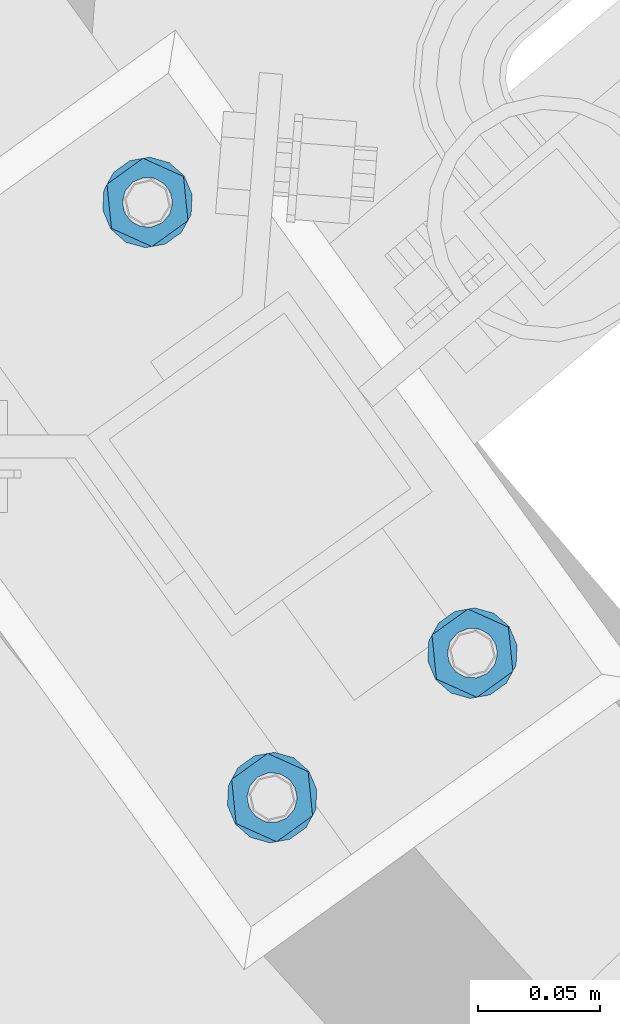
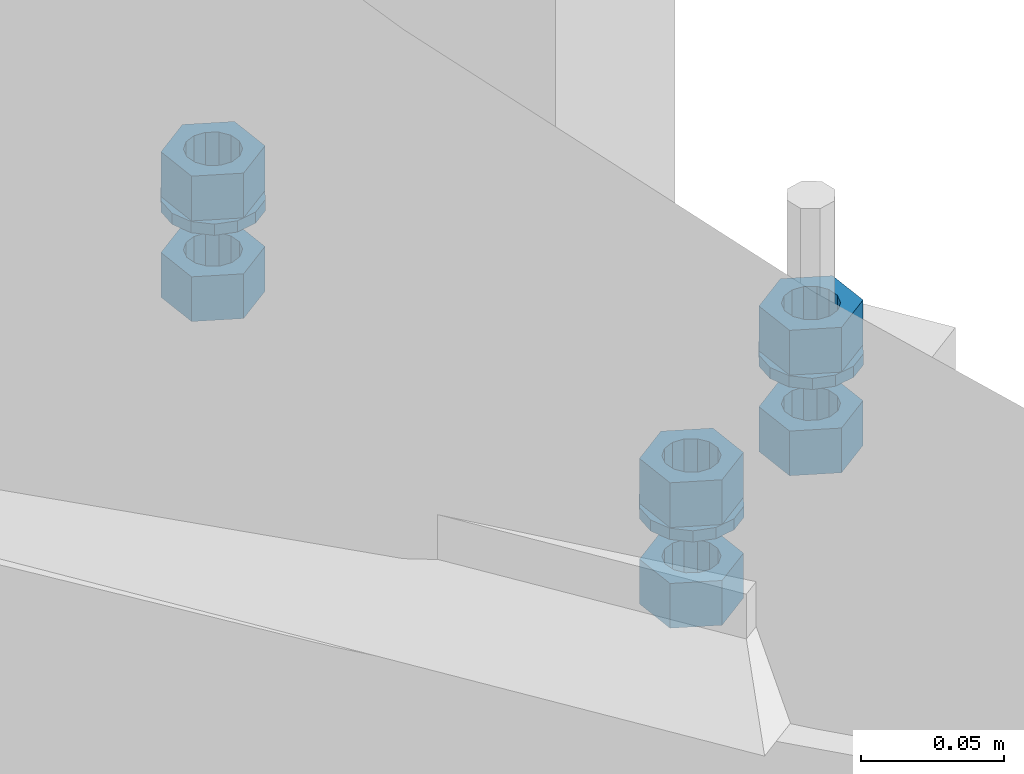
# One storey, part 658 of 975: 9 beams.
"""IFC2X3 building model written with IfcOpenShell, lengths in millimetres."""

from ifc_helpers import new_model, si_unit, frame, origin_with_axes, place, context, subcontext, project, spatial, faceted_brep, material, type_object, element, save


model = new_model("IFC2X3")

# Units and contexts
model_context = context("Model", 3, precision=1e-05, world=origin_with_axes())
body_context = subcontext(model_context, "Body", "Model", "MODEL_VIEW")
ifc_project = project(units=[si_unit("LENGTHUNIT", "METRE", prefix="MILLI"), si_unit("AREAUNIT", "SQUARE_METRE"), si_unit("VOLUMEUNIT", "CUBIC_METRE"), si_unit("MASSUNIT", "GRAM", prefix="KILO"), si_unit("TIMEUNIT", "SECOND"), si_unit("PLANEANGLEUNIT", "RADIAN"), si_unit("SOLIDANGLEUNIT", "STERADIAN"), si_unit("THERMODYNAMICTEMPERATUREUNIT", "DEGREE_CELSIUS"), si_unit("LUMINOUSINTENSITYUNIT", "LUMEN")], contexts=[model_context])

# Site, building, storey
site_placement = place(None, origin_with_axes())
site = spatial("IfcSite", under=ifc_project, at=site_placement, CompositionType="ELEMENT")
building_placement = place(site_placement, origin_with_axes())
building = spatial("IfcBuilding", under=site, at=building_placement, Name="Undefined", CompositionType="ELEMENT")
storey_placement = place(building_placement, origin_with_axes())
storey = spatial("IfcBuildingStorey", under=building, at=storey_placement, Name="Undefined", CompositionType="ELEMENT", Elevation=0.0)

# Beams
ifc_material = material(Name="STEEL/A36")
beam_type_1 = type_object("IfcBeamType", Name="3/4_WASHER", PredefinedType="NOTDEFINED")
beam_1_placement = place(storey_placement, frame((32237.717041171, 1287.18588232323, 1433.51249705359), z_axis=(-0.584817058957379, 0.811165215940897, 0.0), x_axis=(0.0, 0.0, -1.0)))
element("IfcBeam", 1, at=beam_1_placement, inside=storey, type_object=beam_type_1, material=ifc_material, Name="WASHER", ObjectType="3/4_WASHER", context=body_context, shape_type="Brep", body=[
    faceted_brep([(0.0, -18.6499996185303, 0.0), (0.0, -16.8030690426876, -8.09193156902904), (4.76250000000073, -16.8030690426876, -8.09193156902904), (4.76250000000073, -18.6499996185303, 0.0), (0.0, -11.6280845668225, -14.5811568497838), (4.76250000000073, -11.6280845668225, -14.5811568497838), (0.0, -4.15001533340001, -18.1824051902857), (4.76250000000073, -4.15001533340001, -18.1824051902857), (0.0, 4.15001533340001, -18.1824051902857), (4.76250000000073, 4.15001533340001, -18.1824051902857), (0.0, 11.6280845668234, -14.5811568497838), (4.76250000000073, 11.6280845668234, -14.5811568497838), (0.0, 16.8030690426876, -8.09193156902904), (4.76250000000073, 16.8030690426876, -8.09193156902904), (0.0, 18.6499996185303, 0.0), (4.76250000000073, 18.6499996185303, 0.0), (0.0, 16.8030690426876, 8.09193156902904), (4.76250000000073, 16.8030690426876, 8.09193156902904), (0.0, 11.6280845668225, 14.5811568497838), (4.76250000000073, 11.6280845668225, 14.5811568497838), (0.0, 4.15001533340001, 18.1824051902857), (4.76250000000073, 4.15001533340001, 18.1824051902857), (0.0, -4.15001533340001, 18.1824051902857), (4.76250000000073, -4.15001533340001, 18.1824051902857), (0.0, -11.6280845668234, 14.5811568497838), (4.76250000000073, -11.6280845668234, 14.5811568497838), (0.0, -16.8030690426876, 8.09193156902904), (4.76250000000073, -16.8030690426876, 8.09193156902904), (0.0, 0.0, 10.3199996948242), (0.0, 4.47768005528269, 9.29799844179911), (4.76250000000073, 4.47768005528269, 9.29799844179911), (4.76250000000073, 0.0, 10.3199996948242), (0.0, 8.06850066047446, 6.43441456490817), (4.76250000000073, 8.06850066047446, 6.43441456490817), (0.0, 10.0612557561917, 2.29641597052117), (4.76250000000073, 10.0612557561917, 2.29641597052117), (0.0, 10.0612557561917, -2.29641597052117), (4.76250000000073, 10.0612557561917, -2.29641597052117), (0.0, 8.06850066047446, -6.43441456490814), (4.76250000000073, 8.06850066047446, -6.43441456490814), (0.0, 4.47768005528269, -9.29799844179908), (4.76250000000073, 4.47768005528269, -9.29799844179908), (0.0, 0.0, -10.3199996948242), (4.76250000000073, 0.0, -10.3199996948242), (0.0, -4.47768005528269, -9.29799844179911), (4.76250000000073, -4.47768005528269, -9.29799844179911), (0.0, -8.06850066047446, -6.43441456490817), (4.76250000000073, -8.06850066047446, -6.43441456490817), (0.0, -10.0612557561917, -2.29641597052117), (4.76250000000073, -10.0612557561917, -2.29641597052117), (0.0, -10.0612557561917, 2.29641597052117), (4.76250000000073, -10.0612557561917, 2.29641597052117), (0.0, -8.06850066047446, 6.43441456490814), (4.76250000000073, -8.06850066047446, 6.43441456490814), (0.0, -4.47768005528269, 9.29799844179908), (4.76250000000073, -4.47768005528269, 9.29799844179908)], [[[0, 1, 2, 3]], [[1, 4, 5, 2]], [[4, 6, 7, 5]], [[6, 8, 9, 7]], [[8, 10, 11, 9]], [[10, 12, 13, 11]], [[12, 14, 15, 13]], [[14, 16, 17, 15]], [[16, 18, 19, 17]], [[18, 20, 21, 19]], [[20, 22, 23, 21]], [[22, 24, 25, 23]], [[24, 26, 27, 25]], [[26, 0, 3, 27]], [[28, 29, 30, 31]], [[29, 32, 33, 30]], [[32, 34, 35, 33]], [[34, 36, 37, 35]], [[36, 38, 39, 37]], [[38, 40, 41, 39]], [[40, 42, 43, 41]], [[42, 44, 45, 43]], [[44, 46, 47, 45]], [[46, 48, 49, 47]], [[48, 50, 51, 49]], [[50, 52, 53, 51]], [[52, 54, 55, 53]], [[54, 28, 31, 55]], [[5, 7, 9, 11, 13, 15, 17, 19, 21, 23, 25, 27, 3, 2], [33, 35, 37, 39, 41, 43, 45, 47, 49, 51, 53, 55, 31, 30]], [[26, 24, 22, 20, 18, 16, 14, 12, 10, 8, 6, 4, 1, 0], [54, 52, 50, 48, 46, 44, 42, 40, 38, 36, 34, 32, 29, 28]]]),
])
beam_2_placement = place(storey_placement, frame((32155.302659264, 1227.76846354077, 1433.51249705359), z_axis=(0.584817065277228, -0.811165211384543, 0.0), x_axis=(0.0, 0.0, -1.0)))
element("IfcBeam", 2, at=beam_2_placement, inside=storey, type_object=beam_type_1, material=ifc_material, Name="WASHER", ObjectType="3/4_WASHER", context=body_context, shape_type="Brep", body=[
    faceted_brep([(0.0, -18.6499996185303, 0.0), (0.0, -16.8030690426876, -8.09193156902904), (4.76250000000073, -16.8030690426876, -8.09193156902904), (4.76250000000073, -18.6499996185303, 0.0), (0.0, -11.6280845668225, -14.5811568497838), (4.76250000000073, -11.6280845668225, -14.5811568497838), (0.0, -4.15001533340001, -18.1824051902857), (4.76250000000073, -4.15001533340001, -18.1824051902857), (0.0, 4.15001533340001, -18.1824051902857), (4.76250000000073, 4.15001533340001, -18.1824051902857), (0.0, 11.6280845668234, -14.5811568497838), (4.76250000000073, 11.6280845668234, -14.5811568497838), (0.0, 16.8030690426876, -8.09193156902904), (4.76250000000073, 16.8030690426876, -8.09193156902904), (0.0, 18.6499996185303, 0.0), (4.76250000000073, 18.6499996185303, 0.0), (0.0, 16.8030690426876, 8.09193156902904), (4.76250000000073, 16.8030690426876, 8.09193156902904), (0.0, 11.6280845668225, 14.5811568497838), (4.76250000000073, 11.6280845668225, 14.5811568497838), (0.0, 4.15001533340001, 18.1824051902857), (4.76250000000073, 4.15001533340001, 18.1824051902857), (0.0, -4.15001533340001, 18.1824051902857), (4.76250000000073, -4.15001533340001, 18.1824051902857), (0.0, -11.6280845668234, 14.5811568497838), (4.76250000000073, -11.6280845668234, 14.5811568497838), (0.0, -16.8030690426876, 8.09193156902904), (4.76250000000073, -16.8030690426876, 8.09193156902904), (0.0, 0.0, 10.3199996948242), (0.0, 4.47768005528269, 9.29799844179911), (4.76250000000073, 4.47768005528269, 9.29799844179911), (4.76250000000073, 0.0, 10.3199996948242), (0.0, 8.06850066047446, 6.43441456490817), (4.76250000000073, 8.06850066047446, 6.43441456490817), (0.0, 10.0612557561917, 2.29641597052117), (4.76250000000073, 10.0612557561917, 2.29641597052117), (0.0, 10.0612557561917, -2.29641597052117), (4.76250000000073, 10.0612557561917, -2.29641597052117), (0.0, 8.06850066047446, -6.43441456490814), (4.76250000000073, 8.06850066047446, -6.43441456490814), (0.0, 4.47768005528269, -9.29799844179908), (4.76250000000073, 4.47768005528269, -9.29799844179908), (0.0, 0.0, -10.3199996948242), (4.76250000000073, 0.0, -10.3199996948242), (0.0, -4.47768005528269, -9.29799844179911), (4.76250000000073, -4.47768005528269, -9.29799844179911), (0.0, -8.06850066047446, -6.43441456490817), (4.76250000000073, -8.06850066047446, -6.43441456490817), (0.0, -10.0612557561917, -2.29641597052117), (4.76250000000073, -10.0612557561917, -2.29641597052117), (0.0, -10.0612557561917, 2.29641597052117), (4.76250000000073, -10.0612557561917, 2.29641597052117), (0.0, -8.06850066047446, 6.43441456490814), (4.76250000000073, -8.06850066047446, 6.43441456490814), (0.0, -4.47768005528269, 9.29799844179908), (4.76250000000073, -4.47768005528269, 9.29799844179908)], [[[0, 1, 2, 3]], [[1, 4, 5, 2]], [[4, 6, 7, 5]], [[6, 8, 9, 7]], [[8, 10, 11, 9]], [[10, 12, 13, 11]], [[12, 14, 15, 13]], [[14, 16, 17, 15]], [[16, 18, 19, 17]], [[18, 20, 21, 19]], [[20, 22, 23, 21]], [[22, 24, 25, 23]], [[24, 26, 27, 25]], [[26, 0, 3, 27]], [[28, 29, 30, 31]], [[29, 32, 33, 30]], [[32, 34, 35, 33]], [[34, 36, 37, 35]], [[36, 38, 39, 37]], [[38, 40, 41, 39]], [[40, 42, 43, 41]], [[42, 44, 45, 43]], [[44, 46, 47, 45]], [[46, 48, 49, 47]], [[48, 50, 51, 49]], [[50, 52, 53, 51]], [[52, 54, 55, 53]], [[54, 28, 31, 55]], [[5, 7, 9, 11, 13, 15, 17, 19, 21, 23, 25, 27, 3, 2], [33, 35, 37, 39, 41, 43, 45, 47, 49, 51, 53, 55, 31, 30]], [[26, 24, 22, 20, 18, 16, 14, 12, 10, 8, 6, 4, 1, 0], [54, 52, 50, 48, 46, 44, 42, 40, 38, 36, 34, 32, 29, 28]]]),
])
beam_3_placement = place(storey_placement, frame((32104.0278600483, 1472.6182496472, 1433.51249705359), z_axis=(-0.584817058957379, 0.811165215940897, 0.0), x_axis=(0.0, 0.0, -1.0)))
element("IfcBeam", 3, at=beam_3_placement, inside=storey, type_object=beam_type_1, material=ifc_material, Name="WASHER", ObjectType="3/4_WASHER", context=body_context, shape_type="Brep", body=[
    faceted_brep([(0.0, -18.6499996185303, 0.0), (0.0, -16.8030690426876, -8.09193156902904), (4.76250000000073, -16.8030690426876, -8.09193156902904), (4.76250000000073, -18.6499996185303, 0.0), (0.0, -11.6280845668225, -14.5811568497838), (4.76250000000073, -11.6280845668225, -14.5811568497838), (0.0, -4.15001533340001, -18.1824051902857), (4.76250000000073, -4.15001533340001, -18.1824051902857), (0.0, 4.15001533340001, -18.1824051902857), (4.76250000000073, 4.15001533340001, -18.1824051902857), (0.0, 11.6280845668234, -14.5811568497838), (4.76250000000073, 11.6280845668234, -14.5811568497838), (0.0, 16.8030690426876, -8.09193156902904), (4.76250000000073, 16.8030690426876, -8.09193156902904), (0.0, 18.6499996185303, 0.0), (4.76250000000073, 18.6499996185303, 0.0), (0.0, 16.8030690426876, 8.09193156902904), (4.76250000000073, 16.8030690426876, 8.09193156902904), (0.0, 11.6280845668225, 14.5811568497838), (4.76250000000073, 11.6280845668225, 14.5811568497838), (0.0, 4.15001533340001, 18.1824051902857), (4.76250000000073, 4.15001533340001, 18.1824051902857), (0.0, -4.15001533340001, 18.1824051902857), (4.76250000000073, -4.15001533340001, 18.1824051902857), (0.0, -11.6280845668234, 14.5811568497838), (4.76250000000073, -11.6280845668234, 14.5811568497838), (0.0, -16.8030690426876, 8.09193156902904), (4.76250000000073, -16.8030690426876, 8.09193156902904), (0.0, 0.0, 10.3199996948242), (0.0, 4.47768005528269, 9.29799844179911), (4.76250000000073, 4.47768005528269, 9.29799844179911), (4.76250000000073, 0.0, 10.3199996948242), (0.0, 8.06850066047446, 6.43441456490817), (4.76250000000073, 8.06850066047446, 6.43441456490817), (0.0, 10.0612557561917, 2.29641597052117), (4.76250000000073, 10.0612557561917, 2.29641597052117), (0.0, 10.0612557561917, -2.29641597052117), (4.76250000000073, 10.0612557561917, -2.29641597052117), (0.0, 8.06850066047446, -6.43441456490814), (4.76250000000073, 8.06850066047446, -6.43441456490814), (0.0, 4.47768005528269, -9.29799844179908), (4.76250000000073, 4.47768005528269, -9.29799844179908), (0.0, 0.0, -10.3199996948242), (4.76250000000073, 0.0, -10.3199996948242), (0.0, -4.47768005528269, -9.29799844179911), (4.76250000000073, -4.47768005528269, -9.29799844179911), (0.0, -8.06850066047446, -6.43441456490817), (4.76250000000073, -8.06850066047446, -6.43441456490817), (0.0, -10.0612557561917, -2.29641597052117), (4.76250000000073, -10.0612557561917, -2.29641597052117), (0.0, -10.0612557561917, 2.29641597052117), (4.76250000000073, -10.0612557561917, 2.29641597052117), (0.0, -8.06850066047446, 6.43441456490814), (4.76250000000073, -8.06850066047446, 6.43441456490814), (0.0, -4.47768005528269, 9.29799844179908), (4.76250000000073, -4.47768005528269, 9.29799844179908)], [[[0, 1, 2, 3]], [[1, 4, 5, 2]], [[4, 6, 7, 5]], [[6, 8, 9, 7]], [[8, 10, 11, 9]], [[10, 12, 13, 11]], [[12, 14, 15, 13]], [[14, 16, 17, 15]], [[16, 18, 19, 17]], [[18, 20, 21, 19]], [[20, 22, 23, 21]], [[22, 24, 25, 23]], [[24, 26, 27, 25]], [[26, 0, 3, 27]], [[28, 29, 30, 31]], [[29, 32, 33, 30]], [[32, 34, 35, 33]], [[34, 36, 37, 35]], [[36, 38, 39, 37]], [[38, 40, 41, 39]], [[40, 42, 43, 41]], [[42, 44, 45, 43]], [[44, 46, 47, 45]], [[46, 48, 49, 47]], [[48, 50, 51, 49]], [[50, 52, 53, 51]], [[52, 54, 55, 53]], [[54, 28, 31, 55]], [[5, 7, 9, 11, 13, 15, 17, 19, 21, 23, 25, 27, 3, 2], [33, 35, 37, 39, 41, 43, 45, 47, 49, 51, 53, 55, 31, 30]], [[26, 24, 22, 20, 18, 16, 14, 12, 10, 8, 6, 4, 1, 0], [54, 52, 50, 48, 46, 44, 42, 40, 38, 36, 34, 32, 29, 28]]]),
])
beam_type_2 = type_object("IfcBeamType", Name="3/4_HEAVY_HEX_NUT", PredefinedType="NOTDEFINED")
beam_4_placement = place(storey_placement, frame((32237.717041171, 1287.18588232323, 1452.56249705359), z_axis=(-0.584817058957379, 0.811165215940897, 0.0), x_axis=(0.0, 0.0, -1.0)))
element("IfcBeam", 4, at=beam_4_placement, inside=storey, type_object=beam_type_2, material=ifc_material, Name="NUT", ObjectType="3/4_HEAVY_HEX_NUT", context=body_context, shape_type="Brep", body=[
    faceted_brep([(0.0, -18.2600002288818, 0.0), (0.0, -9.13000011444092, -15.8100004196167), (19.0499999999993, -9.13000011444092, -15.8100004196167), (19.0499999999993, -18.2600002288818, 0.0), (0.0, 9.13000011444092, -15.8100004196167), (19.0499999999993, 9.13000011444092, -15.8100004196167), (0.0, 18.2600002288818, 0.0), (19.0499999999993, 18.2600002288818, 0.0), (0.0, 9.13000011444092, 15.8100004196167), (19.0499999999993, 9.13000011444092, 15.8100004196167), (0.0, -9.13000011444092, 15.8100004196167), (19.0499999999993, -9.13000011444092, 15.8100004196167), (0.0, 0.0, 10.3199996948242), (0.0, 4.47768005528269, 9.29799844179911), (19.0499999999993, 4.47768005528269, 9.29799844179911), (19.0499999999993, 0.0, 10.3199996948242), (0.0, 8.06850066047446, 6.43441456490817), (19.0499999999993, 8.06850066047446, 6.43441456490817), (0.0, 10.0612557561917, 2.29641597052117), (19.0499999999993, 10.0612557561917, 2.29641597052117), (0.0, 10.0612557561917, -2.29641597052117), (19.0499999999993, 10.0612557561917, -2.29641597052117), (0.0, 8.06850066047446, -6.43441456490814), (19.0499999999993, 8.06850066047446, -6.43441456490814), (0.0, 4.47768005528269, -9.29799844179908), (19.0499999999993, 4.47768005528269, -9.29799844179908), (0.0, 0.0, -10.3199996948242), (19.0499999999993, 0.0, -10.3199996948242), (0.0, -4.47768005528269, -9.29799844179911), (19.0499999999993, -4.47768005528269, -9.29799844179911), (0.0, -8.06850066047446, -6.43441456490817), (19.0499999999993, -8.06850066047446, -6.43441456490817), (0.0, -10.0612557561917, -2.29641597052117), (19.0499999999993, -10.0612557561917, -2.29641597052117), (0.0, -10.0612557561917, 2.29641597052117), (19.0499999999993, -10.0612557561917, 2.29641597052117), (0.0, -8.06850066047446, 6.43441456490814), (19.0499999999993, -8.06850066047446, 6.43441456490814), (0.0, -4.47768005528269, 9.29799844179908), (19.0499999999993, -4.47768005528269, 9.29799844179908)], [[[0, 1, 2, 3]], [[1, 4, 5, 2]], [[4, 6, 7, 5]], [[6, 8, 9, 7]], [[8, 10, 11, 9]], [[10, 0, 3, 11]], [[12, 13, 14, 15]], [[13, 16, 17, 14]], [[16, 18, 19, 17]], [[18, 20, 21, 19]], [[20, 22, 23, 21]], [[22, 24, 25, 23]], [[24, 26, 27, 25]], [[26, 28, 29, 27]], [[28, 30, 31, 29]], [[30, 32, 33, 31]], [[32, 34, 35, 33]], [[34, 36, 37, 35]], [[36, 38, 39, 37]], [[38, 12, 15, 39]], [[5, 7, 9, 11, 3, 2], [17, 19, 21, 23, 25, 27, 29, 31, 33, 35, 37, 39, 15, 14]], [[10, 8, 6, 4, 1, 0], [38, 36, 34, 32, 30, 28, 26, 24, 22, 20, 18, 16, 13, 12]]]),
])
beam_5_placement = place(storey_placement, frame((32237.717041171, 1287.18588232323, 1409.69999705359), z_axis=(-0.584817058957379, 0.811165215940897, 0.0), x_axis=(0.0, 0.0, -1.0)))
element("IfcBeam", 5, at=beam_5_placement, inside=storey, type_object=beam_type_2, material=ifc_material, Name="NUT", ObjectType="3/4_HEAVY_HEX_NUT", context=body_context, shape_type="Brep", body=[
    faceted_brep([(0.0, -18.2600002288818, 0.0), (0.0, -9.13000011444092, -15.8100004196167), (19.0499999999993, -9.13000011444092, -15.8100004196167), (19.0499999999993, -18.2600002288818, 0.0), (0.0, 9.13000011444092, -15.8100004196167), (19.0499999999993, 9.13000011444092, -15.8100004196167), (0.0, 18.2600002288818, 0.0), (19.0499999999993, 18.2600002288818, 0.0), (0.0, 9.13000011444092, 15.8100004196167), (19.0499999999993, 9.13000011444092, 15.8100004196167), (0.0, -9.13000011444092, 15.8100004196167), (19.0499999999993, -9.13000011444092, 15.8100004196167), (0.0, 0.0, 10.3199996948242), (0.0, 4.47768005528269, 9.29799844179911), (19.0499999999993, 4.47768005528269, 9.29799844179911), (19.0499999999993, 0.0, 10.3199996948242), (0.0, 8.06850066047446, 6.43441456490817), (19.0499999999993, 8.06850066047446, 6.43441456490817), (0.0, 10.0612557561917, 2.29641597052117), (19.0499999999993, 10.0612557561917, 2.29641597052117), (0.0, 10.0612557561917, -2.29641597052117), (19.0499999999993, 10.0612557561917, -2.29641597052117), (0.0, 8.06850066047446, -6.43441456490814), (19.0499999999993, 8.06850066047446, -6.43441456490814), (0.0, 4.47768005528269, -9.29799844179908), (19.0499999999993, 4.47768005528269, -9.29799844179908), (0.0, 0.0, -10.3199996948242), (19.0499999999993, 0.0, -10.3199996948242), (0.0, -4.47768005528269, -9.29799844179911), (19.0499999999993, -4.47768005528269, -9.29799844179911), (0.0, -8.06850066047446, -6.43441456490817), (19.0499999999993, -8.06850066047446, -6.43441456490817), (0.0, -10.0612557561917, -2.29641597052117), (19.0499999999993, -10.0612557561917, -2.29641597052117), (0.0, -10.0612557561917, 2.29641597052117), (19.0499999999993, -10.0612557561917, 2.29641597052117), (0.0, -8.06850066047446, 6.43441456490814), (19.0499999999993, -8.06850066047446, 6.43441456490814), (0.0, -4.47768005528269, 9.29799844179908), (19.0499999999993, -4.47768005528269, 9.29799844179908)], [[[0, 1, 2, 3]], [[1, 4, 5, 2]], [[4, 6, 7, 5]], [[6, 8, 9, 7]], [[8, 10, 11, 9]], [[10, 0, 3, 11]], [[12, 13, 14, 15]], [[13, 16, 17, 14]], [[16, 18, 19, 17]], [[18, 20, 21, 19]], [[20, 22, 23, 21]], [[22, 24, 25, 23]], [[24, 26, 27, 25]], [[26, 28, 29, 27]], [[28, 30, 31, 29]], [[30, 32, 33, 31]], [[32, 34, 35, 33]], [[34, 36, 37, 35]], [[36, 38, 39, 37]], [[38, 12, 15, 39]], [[5, 7, 9, 11, 3, 2], [17, 19, 21, 23, 25, 27, 29, 31, 33, 35, 37, 39, 15, 14]], [[10, 8, 6, 4, 1, 0], [38, 36, 34, 32, 30, 28, 26, 24, 22, 20, 18, 16, 13, 12]]]),
])
beam_6_placement = place(storey_placement, frame((32155.302659264, 1227.76846354077, 1452.56249705359), z_axis=(0.584817065277228, -0.811165211384543, 0.0), x_axis=(0.0, 0.0, -1.0)))
element("IfcBeam", 6, at=beam_6_placement, inside=storey, type_object=beam_type_2, material=ifc_material, Name="NUT", ObjectType="3/4_HEAVY_HEX_NUT", context=body_context, shape_type="Brep", body=[
    faceted_brep([(0.0, -18.2600002288818, 0.0), (0.0, -9.13000011444092, -15.8100004196167), (19.0499999999993, -9.13000011444092, -15.8100004196167), (19.0499999999993, -18.2600002288818, 0.0), (0.0, 9.13000011444092, -15.8100004196167), (19.0499999999993, 9.13000011444092, -15.8100004196167), (0.0, 18.2600002288818, 0.0), (19.0499999999993, 18.2600002288818, 0.0), (0.0, 9.13000011444092, 15.8100004196167), (19.0499999999993, 9.13000011444092, 15.8100004196167), (0.0, -9.13000011444092, 15.8100004196167), (19.0499999999993, -9.13000011444092, 15.8100004196167), (0.0, 0.0, 10.3199996948242), (0.0, 4.47768005528269, 9.29799844179911), (19.0499999999993, 4.47768005528269, 9.29799844179911), (19.0499999999993, 0.0, 10.3199996948242), (0.0, 8.06850066047446, 6.43441456490817), (19.0499999999993, 8.06850066047446, 6.43441456490817), (0.0, 10.0612557561917, 2.29641597052117), (19.0499999999993, 10.0612557561917, 2.29641597052117), (0.0, 10.0612557561917, -2.29641597052117), (19.0499999999993, 10.0612557561917, -2.29641597052117), (0.0, 8.06850066047446, -6.43441456490814), (19.0499999999993, 8.06850066047446, -6.43441456490814), (0.0, 4.47768005528269, -9.29799844179908), (19.0499999999993, 4.47768005528269, -9.29799844179908), (0.0, 0.0, -10.3199996948242), (19.0499999999993, 0.0, -10.3199996948242), (0.0, -4.47768005528269, -9.29799844179911), (19.0499999999993, -4.47768005528269, -9.29799844179911), (0.0, -8.06850066047446, -6.43441456490817), (19.0499999999993, -8.06850066047446, -6.43441456490817), (0.0, -10.0612557561917, -2.29641597052117), (19.0499999999993, -10.0612557561917, -2.29641597052117), (0.0, -10.0612557561917, 2.29641597052117), (19.0499999999993, -10.0612557561917, 2.29641597052117), (0.0, -8.06850066047446, 6.43441456490814), (19.0499999999993, -8.06850066047446, 6.43441456490814), (0.0, -4.47768005528269, 9.29799844179908), (19.0499999999993, -4.47768005528269, 9.29799844179908)], [[[0, 1, 2, 3]], [[1, 4, 5, 2]], [[4, 6, 7, 5]], [[6, 8, 9, 7]], [[8, 10, 11, 9]], [[10, 0, 3, 11]], [[12, 13, 14, 15]], [[13, 16, 17, 14]], [[16, 18, 19, 17]], [[18, 20, 21, 19]], [[20, 22, 23, 21]], [[22, 24, 25, 23]], [[24, 26, 27, 25]], [[26, 28, 29, 27]], [[28, 30, 31, 29]], [[30, 32, 33, 31]], [[32, 34, 35, 33]], [[34, 36, 37, 35]], [[36, 38, 39, 37]], [[38, 12, 15, 39]], [[5, 7, 9, 11, 3, 2], [17, 19, 21, 23, 25, 27, 29, 31, 33, 35, 37, 39, 15, 14]], [[10, 8, 6, 4, 1, 0], [38, 36, 34, 32, 30, 28, 26, 24, 22, 20, 18, 16, 13, 12]]]),
])
beam_7_placement = place(storey_placement, frame((32104.0278600483, 1472.6182496472, 1452.56249705359), z_axis=(-0.584817058957379, 0.811165215940897, 0.0), x_axis=(0.0, 0.0, -1.0)))
element("IfcBeam", 7, at=beam_7_placement, inside=storey, type_object=beam_type_2, material=ifc_material, Name="NUT", ObjectType="3/4_HEAVY_HEX_NUT", context=body_context, shape_type="Brep", body=[
    faceted_brep([(0.0, -18.2600002288818, 0.0), (0.0, -9.13000011444092, -15.8100004196167), (19.0499999999993, -9.13000011444092, -15.8100004196167), (19.0499999999993, -18.2600002288818, 0.0), (0.0, 9.13000011444092, -15.8100004196167), (19.0499999999993, 9.13000011444092, -15.8100004196167), (0.0, 18.2600002288818, 0.0), (19.0499999999993, 18.2600002288818, 0.0), (0.0, 9.13000011444092, 15.8100004196167), (19.0499999999993, 9.13000011444092, 15.8100004196167), (0.0, -9.13000011444092, 15.8100004196167), (19.0499999999993, -9.13000011444092, 15.8100004196167), (0.0, 0.0, 10.3199996948242), (0.0, 4.47768005528269, 9.29799844179911), (19.0499999999993, 4.47768005528269, 9.29799844179911), (19.0499999999993, 0.0, 10.3199996948242), (0.0, 8.06850066047446, 6.43441456490817), (19.0499999999993, 8.06850066047446, 6.43441456490817), (0.0, 10.0612557561917, 2.29641597052117), (19.0499999999993, 10.0612557561917, 2.29641597052117), (0.0, 10.0612557561917, -2.29641597052117), (19.0499999999993, 10.0612557561917, -2.29641597052117), (0.0, 8.06850066047446, -6.43441456490814), (19.0499999999993, 8.06850066047446, -6.43441456490814), (0.0, 4.47768005528269, -9.29799844179908), (19.0499999999993, 4.47768005528269, -9.29799844179908), (0.0, 0.0, -10.3199996948242), (19.0499999999993, 0.0, -10.3199996948242), (0.0, -4.47768005528269, -9.29799844179911), (19.0499999999993, -4.47768005528269, -9.29799844179911), (0.0, -8.06850066047446, -6.43441456490817), (19.0499999999993, -8.06850066047446, -6.43441456490817), (0.0, -10.0612557561917, -2.29641597052117), (19.0499999999993, -10.0612557561917, -2.29641597052117), (0.0, -10.0612557561917, 2.29641597052117), (19.0499999999993, -10.0612557561917, 2.29641597052117), (0.0, -8.06850066047446, 6.43441456490814), (19.0499999999993, -8.06850066047446, 6.43441456490814), (0.0, -4.47768005528269, 9.29799844179908), (19.0499999999993, -4.47768005528269, 9.29799844179908)], [[[0, 1, 2, 3]], [[1, 4, 5, 2]], [[4, 6, 7, 5]], [[6, 8, 9, 7]], [[8, 10, 11, 9]], [[10, 0, 3, 11]], [[12, 13, 14, 15]], [[13, 16, 17, 14]], [[16, 18, 19, 17]], [[18, 20, 21, 19]], [[20, 22, 23, 21]], [[22, 24, 25, 23]], [[24, 26, 27, 25]], [[26, 28, 29, 27]], [[28, 30, 31, 29]], [[30, 32, 33, 31]], [[32, 34, 35, 33]], [[34, 36, 37, 35]], [[36, 38, 39, 37]], [[38, 12, 15, 39]], [[5, 7, 9, 11, 3, 2], [17, 19, 21, 23, 25, 27, 29, 31, 33, 35, 37, 39, 15, 14]], [[10, 8, 6, 4, 1, 0], [38, 36, 34, 32, 30, 28, 26, 24, 22, 20, 18, 16, 13, 12]]]),
])
beam_8_placement = place(storey_placement, frame((32155.302659264, 1227.76846354077, 1409.69999705359), z_axis=(0.584817065277228, -0.811165211384543, 0.0), x_axis=(0.0, 0.0, -1.0)))
element("IfcBeam", 8, at=beam_8_placement, inside=storey, type_object=beam_type_2, material=ifc_material, Name="NUT", ObjectType="3/4_HEAVY_HEX_NUT", context=body_context, shape_type="Brep", body=[
    faceted_brep([(0.0, -18.2600002288818, 0.0), (0.0, -9.13000011444092, -15.8100004196167), (19.0499999999993, -9.13000011444092, -15.8100004196167), (19.0499999999993, -18.2600002288818, 0.0), (0.0, 9.13000011444092, -15.8100004196167), (19.0499999999993, 9.13000011444092, -15.8100004196167), (0.0, 18.2600002288818, 0.0), (19.0499999999993, 18.2600002288818, 0.0), (0.0, 9.13000011444092, 15.8100004196167), (19.0499999999993, 9.13000011444092, 15.8100004196167), (0.0, -9.13000011444092, 15.8100004196167), (19.0499999999993, -9.13000011444092, 15.8100004196167), (0.0, 0.0, 10.3199996948242), (0.0, 4.47768005528269, 9.29799844179911), (19.0499999999993, 4.47768005528269, 9.29799844179911), (19.0499999999993, 0.0, 10.3199996948242), (0.0, 8.06850066047446, 6.43441456490817), (19.0499999999993, 8.06850066047446, 6.43441456490817), (0.0, 10.0612557561917, 2.29641597052117), (19.0499999999993, 10.0612557561917, 2.29641597052117), (0.0, 10.0612557561917, -2.29641597052117), (19.0499999999993, 10.0612557561917, -2.29641597052117), (0.0, 8.06850066047446, -6.43441456490814), (19.0499999999993, 8.06850066047446, -6.43441456490814), (0.0, 4.47768005528269, -9.29799844179908), (19.0499999999993, 4.47768005528269, -9.29799844179908), (0.0, 0.0, -10.3199996948242), (19.0499999999993, 0.0, -10.3199996948242), (0.0, -4.47768005528269, -9.29799844179911), (19.0499999999993, -4.47768005528269, -9.29799844179911), (0.0, -8.06850066047446, -6.43441456490817), (19.0499999999993, -8.06850066047446, -6.43441456490817), (0.0, -10.0612557561917, -2.29641597052117), (19.0499999999993, -10.0612557561917, -2.29641597052117), (0.0, -10.0612557561917, 2.29641597052117), (19.0499999999993, -10.0612557561917, 2.29641597052117), (0.0, -8.06850066047446, 6.43441456490814), (19.0499999999993, -8.06850066047446, 6.43441456490814), (0.0, -4.47768005528269, 9.29799844179908), (19.0499999999993, -4.47768005528269, 9.29799844179908)], [[[0, 1, 2, 3]], [[1, 4, 5, 2]], [[4, 6, 7, 5]], [[6, 8, 9, 7]], [[8, 10, 11, 9]], [[10, 0, 3, 11]], [[12, 13, 14, 15]], [[13, 16, 17, 14]], [[16, 18, 19, 17]], [[18, 20, 21, 19]], [[20, 22, 23, 21]], [[22, 24, 25, 23]], [[24, 26, 27, 25]], [[26, 28, 29, 27]], [[28, 30, 31, 29]], [[30, 32, 33, 31]], [[32, 34, 35, 33]], [[34, 36, 37, 35]], [[36, 38, 39, 37]], [[38, 12, 15, 39]], [[5, 7, 9, 11, 3, 2], [17, 19, 21, 23, 25, 27, 29, 31, 33, 35, 37, 39, 15, 14]], [[10, 8, 6, 4, 1, 0], [38, 36, 34, 32, 30, 28, 26, 24, 22, 20, 18, 16, 13, 12]]]),
])
beam_9_placement = place(storey_placement, frame((32104.0278600483, 1472.6182496472, 1409.69999705359), z_axis=(-0.584817058957379, 0.811165215940897, 0.0), x_axis=(0.0, 0.0, -1.0)))
element("IfcBeam", 9, at=beam_9_placement, inside=storey, type_object=beam_type_2, material=ifc_material, Name="NUT", ObjectType="3/4_HEAVY_HEX_NUT", context=body_context, shape_type="Brep", body=[
    faceted_brep([(0.0, -18.2600002288818, 0.0), (0.0, -9.13000011444092, -15.8100004196167), (19.0499999999993, -9.13000011444092, -15.8100004196167), (19.0499999999993, -18.2600002288818, 0.0), (0.0, 9.13000011444092, -15.8100004196167), (19.0499999999993, 9.13000011444092, -15.8100004196167), (0.0, 18.2600002288818, 0.0), (19.0499999999993, 18.2600002288818, 0.0), (0.0, 9.13000011444092, 15.8100004196167), (19.0499999999993, 9.13000011444092, 15.8100004196167), (0.0, -9.13000011444092, 15.8100004196167), (19.0499999999993, -9.13000011444092, 15.8100004196167), (0.0, 0.0, 10.3199996948242), (0.0, 4.47768005528269, 9.29799844179911), (19.0499999999993, 4.47768005528269, 9.29799844179911), (19.0499999999993, 0.0, 10.3199996948242), (0.0, 8.06850066047446, 6.43441456490817), (19.0499999999993, 8.06850066047446, 6.43441456490817), (0.0, 10.0612557561917, 2.29641597052117), (19.0499999999993, 10.0612557561917, 2.29641597052117), (0.0, 10.0612557561917, -2.29641597052117), (19.0499999999993, 10.0612557561917, -2.29641597052117), (0.0, 8.06850066047446, -6.43441456490814), (19.0499999999993, 8.06850066047446, -6.43441456490814), (0.0, 4.47768005528269, -9.29799844179908), (19.0499999999993, 4.47768005528269, -9.29799844179908), (0.0, 0.0, -10.3199996948242), (19.0499999999993, 0.0, -10.3199996948242), (0.0, -4.47768005528269, -9.29799844179911), (19.0499999999993, -4.47768005528269, -9.29799844179911), (0.0, -8.06850066047446, -6.43441456490817), (19.0499999999993, -8.06850066047446, -6.43441456490817), (0.0, -10.0612557561917, -2.29641597052117), (19.0499999999993, -10.0612557561917, -2.29641597052117), (0.0, -10.0612557561917, 2.29641597052117), (19.0499999999993, -10.0612557561917, 2.29641597052117), (0.0, -8.06850066047446, 6.43441456490814), (19.0499999999993, -8.06850066047446, 6.43441456490814), (0.0, -4.47768005528269, 9.29799844179908), (19.0499999999993, -4.47768005528269, 9.29799844179908)], [[[0, 1, 2, 3]], [[1, 4, 5, 2]], [[4, 6, 7, 5]], [[6, 8, 9, 7]], [[8, 10, 11, 9]], [[10, 0, 3, 11]], [[12, 13, 14, 15]], [[13, 16, 17, 14]], [[16, 18, 19, 17]], [[18, 20, 21, 19]], [[20, 22, 23, 21]], [[22, 24, 25, 23]], [[24, 26, 27, 25]], [[26, 28, 29, 27]], [[28, 30, 31, 29]], [[30, 32, 33, 31]], [[32, 34, 35, 33]], [[34, 36, 37, 35]], [[36, 38, 39, 37]], [[38, 12, 15, 39]], [[5, 7, 9, 11, 3, 2], [17, 19, 21, 23, 25, 27, 29, 31, 33, 35, 37, 39, 15, 14]], [[10, 8, 6, 4, 1, 0], [38, 36, 34, 32, 30, 28, 26, 24, 22, 20, 18, 16, 13, 12]]]),
])

save(model, "model.ifc")
